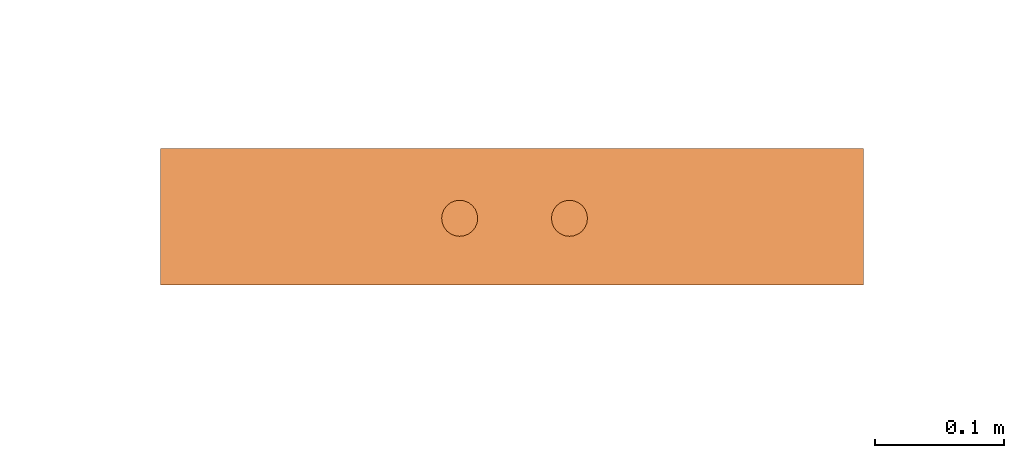
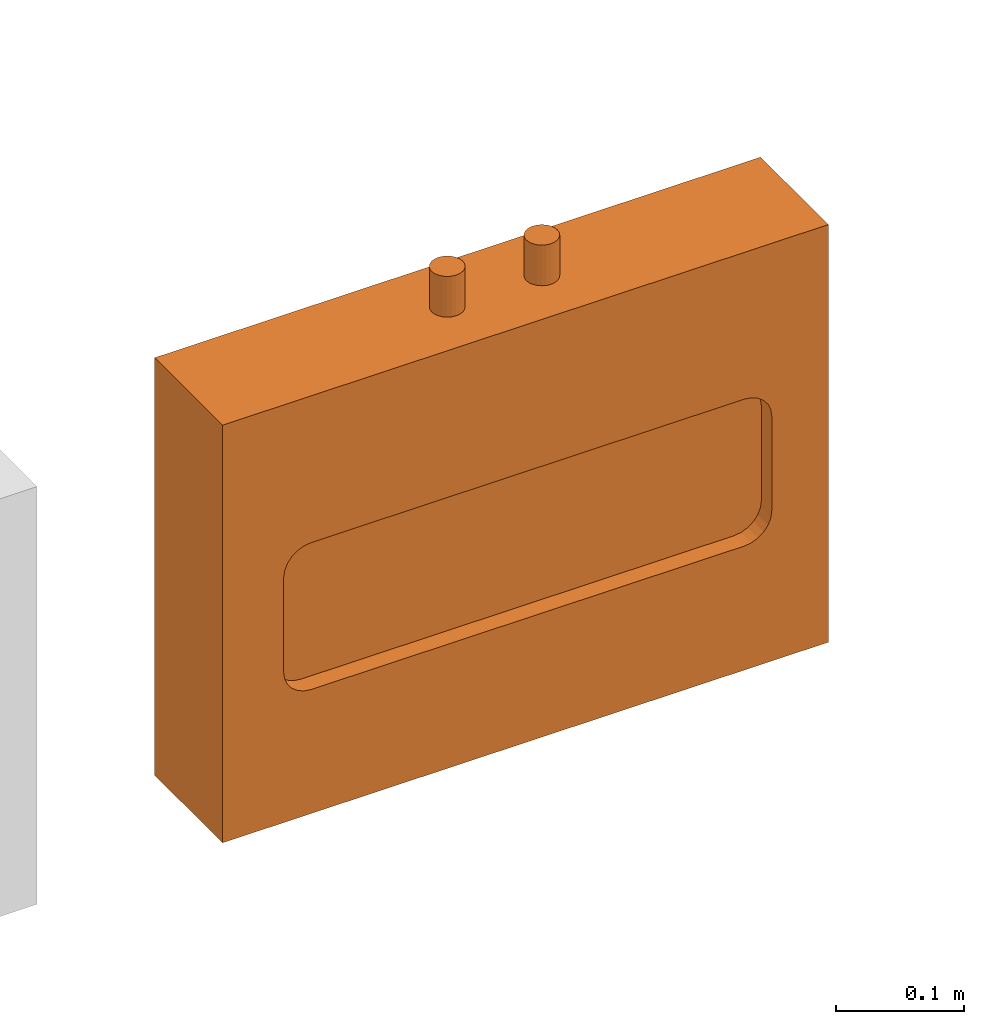
# One storey, part 5 of 5: 1 proxy.
"""IFC2X3 building model written with IfcOpenShell, lengths in millimetres."""

from ifc_helpers import new_model, entity, si_unit, converted_unit, derived_unit, direction, frame, origin, place, context, subcontext, project, spatial, faceted_brep, source, transform, mapped, material, material_list, type_object, type_shapes, element, save


model = new_model("IFC2X3")

# Units and contexts
model_context = context("Model", 3, precision=0.01, world=origin(), true_north=direction((6.12303176911189e-17, 1.0)))
body_context = subcontext(model_context, "Body", "Model", "MODEL_VIEW")
ifc_project = project(units=[si_unit("LENGTHUNIT", "METRE", prefix="MILLI"), si_unit("AREAUNIT", "SQUARE_METRE"), si_unit("VOLUMEUNIT", "CUBIC_METRE"), converted_unit("PLANEANGLEUNIT", "DEGREE", entity("IfcRatioMeasure", 0.0174532925199433), si_unit("PLANEANGLEUNIT", "RADIAN"), dimensions=[0, 0, 0, 0, 0, 0, 0]), si_unit("MASSUNIT", "GRAM", prefix="KILO"), derived_unit("MASSDENSITYUNIT", [(si_unit("MASSUNIT", "GRAM", prefix="KILO"), 1), (si_unit("LENGTHUNIT", "METRE"), -3)]), derived_unit("MOMENTOFINERTIAUNIT", [(si_unit("LENGTHUNIT", "METRE"), 4)]), si_unit("TIMEUNIT", "SECOND"), si_unit("FREQUENCYUNIT", "HERTZ"), si_unit("THERMODYNAMICTEMPERATUREUNIT", "DEGREE_CELSIUS"), derived_unit("THERMALTRANSMITTANCEUNIT", [(si_unit("MASSUNIT", "GRAM", prefix="KILO"), 1), (si_unit("THERMODYNAMICTEMPERATUREUNIT", "KELVIN"), -1), (si_unit("TIMEUNIT", "SECOND"), -3)]), derived_unit("VOLUMETRICFLOWRATEUNIT", [(si_unit("LENGTHUNIT", "METRE"), 3), (si_unit("TIMEUNIT", "SECOND"), -1)]), derived_unit("MASSFLOWRATEUNIT", [(si_unit("MASSUNIT", "GRAM", prefix="KILO"), 1), (si_unit("TIMEUNIT", "SECOND"), -1)]), derived_unit("ROTATIONALFREQUENCYUNIT", [(si_unit("TIMEUNIT", "SECOND"), -1)]), si_unit("ELECTRICCURRENTUNIT", "AMPERE"), si_unit("ELECTRICVOLTAGEUNIT", "VOLT"), si_unit("POWERUNIT", "WATT"), si_unit("FORCEUNIT", "NEWTON", prefix="KILO"), si_unit("ILLUMINANCEUNIT", "LUX"), si_unit("LUMINOUSFLUXUNIT", "LUMEN"), si_unit("LUMINOUSINTENSITYUNIT", "CANDELA"), derived_unit("USERDEFINED", [(si_unit("MASSUNIT", "GRAM", prefix="KILO"), -1), (si_unit("LENGTHUNIT", "METRE"), -2), (si_unit("TIMEUNIT", "SECOND"), 3), (si_unit("LUMINOUSFLUXUNIT", "LUMEN"), 1)]), derived_unit("LINEARVELOCITYUNIT", [(si_unit("LENGTHUNIT", "METRE"), 1), (si_unit("TIMEUNIT", "SECOND"), -1)]), si_unit("PRESSUREUNIT", "PASCAL"), derived_unit("USERDEFINED", [(si_unit("LENGTHUNIT", "METRE"), -2), (si_unit("MASSUNIT", "GRAM", prefix="KILO"), 1), (si_unit("TIMEUNIT", "SECOND"), -2)]), derived_unit("LINEARFORCEUNIT", [(si_unit("MASSUNIT", "GRAM", prefix="KILO"), 1), (si_unit("LENGTHUNIT", "METRE"), 1), (si_unit("TIMEUNIT", "SECOND"), -2), (si_unit("LENGTHUNIT", "METRE"), -1)]), derived_unit("PLANARFORCEUNIT", [(si_unit("MASSUNIT", "GRAM", prefix="KILO"), 1), (si_unit("LENGTHUNIT", "METRE"), 1), (si_unit("TIMEUNIT", "SECOND"), -2), (si_unit("LENGTHUNIT", "METRE"), -2)])], contexts=[model_context])

# Site, building, storey
site_placement = place(None, frame((0.0, 2493.83037508239, 0.0)))
site = spatial("IfcSite", under=ifc_project, at=site_placement, CompositionType="ELEMENT")
building_placement = place(site_placement, origin())
building = spatial("IfcBuilding", under=site, at=building_placement, CompositionType="ELEMENT")
storey_placement = place(building_placement, frame((0.0, 0.0, 19800.0)))
storey = spatial("IfcBuildingStorey", under=building, at=storey_placement, Name="06", CompositionType="ELEMENT", Elevation=19800.0)

# Proxy
ifc_material_1 = material()
ifc_material_2 = material()
ifc_material_list = material_list([ifc_material_1, ifc_material_2])
building_element_proxy_type = type_object("IfcBuildingElementProxyType", PredefinedType="NOTDEFINED", material=ifc_material_1)
shared_shape = source(origin(), body_context, "Body", "Brep", [
    faceted_brep([(55.460649399612, 241.868036996809, 398.0), (58.8371827681767, 240.469431081744, 398.0), (61.7366777047884, 238.244570365374, 398.0), (63.9615384211588, 235.345075428762, 398.0), (65.3601443362237, 231.968542060197, 398.0), (65.8371827681767, 228.345075428762, 398.0), (65.3601443362236, 224.721608797327, 398.0), (63.9615384211588, 221.345075428762, 398.0), (61.7366777047883, 218.44558049215, 398.0), (58.8371827681766, 216.22071977578, 398.0), (55.4606493996119, 214.822113860715, 398.0), (51.8371827681766, 214.345075428762, 398.0), (48.2137161367414, 214.822113860715, 398.0), (44.8371827681767, 216.22071977578, 398.0), (41.937687831565, 218.44558049215, 398.0), (39.7128271151945, 221.345075428762, 398.0), (38.3142212001297, 224.721608797327, 398.0), (37.8371827681767, 228.345075428762, 398.0), (38.3142212001298, 231.968542060197, 398.0), (39.7128271151946, 235.345075428762, 398.0), (41.9376878315651, 238.244570365374, 398.0), (44.8371827681767, 240.469431081744, 398.0), (48.2137161367414, 241.868036996809, 398.0), (51.8371827681767, 242.345075428762, 398.0), (58.8371827681766, 216.22071977578, 436.716690815491), (61.7366777047883, 218.44558049215, 436.716690815491), (63.9615384211588, 221.345075428762, 436.716690815491), (65.3601443362236, 224.721608797327, 436.716690815491), (65.8371827681767, 228.345075428762, 436.716690815491), (65.3601443362237, 231.968542060197, 436.716690815491), (63.9615384211588, 235.345075428762, 436.716690815491), (61.7366777047884, 238.244570365374, 436.716690815491), (58.8371827681767, 240.469431081744, 436.716690815491), (55.460649399612, 241.868036996809, 436.716690815491), (51.8371827681767, 242.345075428762, 436.716690815491), (48.2137161367414, 241.868036996809, 436.716690815491), (44.8371827681767, 240.469431081744, 436.716690815491), (41.9376878315651, 238.244570365374, 436.716690815491), (39.7128271151946, 235.345075428762, 436.716690815491), (38.3142212001298, 231.968542060197, 436.716690815491), (37.8371827681767, 228.345075428762, 436.716690815491), (38.3142212001297, 224.721608797327, 436.716690815491), (39.7128271151945, 221.345075428762, 436.716690815491), (41.937687831565, 218.44558049215, 436.716690815491), (44.8371827681767, 216.22071977578, 436.716690815491), (48.2137161367414, 214.822113860715, 436.716690815491), (51.8371827681766, 214.345075428762, 436.716690815491), (55.4606493996119, 214.822113860715, 436.716690815491)], [[[0, 1, 2, 3, 4, 5, 6, 7, 8, 9, 10, 11, 12, 13, 14, 15, 16, 17, 18, 19, 20, 21, 22, 23]], [[24, 25, 26, 27, 28, 29, 30, 31, 32, 33, 34, 35, 36, 37, 38, 39, 40, 41, 42, 43, 44, 45, 46, 47]], [[40, 17, 16, 41]], [[15, 42, 41, 16]], [[43, 14, 13, 44]], [[15, 14, 43, 42]], [[44, 13, 12, 45]], [[11, 46, 45, 12]], [[47, 10, 9, 24]], [[8, 25, 24, 9]], [[26, 7, 6, 27]], [[8, 7, 26, 25]], [[27, 6, 5, 28]], [[47, 46, 11, 10]], [[28, 5, 4, 29]], [[3, 30, 29, 4]], [[31, 2, 1, 32]], [[3, 2, 31, 30]], [[32, 1, 0, 33]], [[23, 34, 33, 0]], [[35, 22, 21, 36]], [[20, 37, 36, 21]], [[38, 19, 18, 39]], [[20, 19, 38, 37]], [[39, 18, 17, 40]], [[35, 34, 23, 22]]]),
    faceted_brep([(58.8371827681766, 301.503571322428, 436.716690815491), (61.7366777047883, 303.728432038799, 436.716690815491), (63.9615384211588, 306.627926975411, 436.716690815491), (65.3601443362236, 310.004460343975, 436.716690815491), (65.8371827681767, 313.627926975411, 436.716690815491), (65.3601443362237, 317.251393606846, 436.716690815491), (63.9615384211589, 320.627926975411, 436.716690815491), (61.7366777047884, 323.527421912022, 436.716690815491), (58.8371827681767, 325.752282628393, 436.716690815491), (55.460649399612, 327.150888543458, 436.716690815491), (51.8371827681767, 327.627926975411, 436.716690815491), (48.2137161367414, 327.150888543458, 436.716690815491), (44.8371827681767, 325.752282628393, 436.716690815491), (41.9376878315651, 323.527421912022, 436.716690815491), (39.7128271151946, 320.627926975411, 436.716690815491), (38.3142212001298, 317.251393606846, 436.716690815491), (37.8371827681767, 313.627926975411, 436.716690815491), (38.3142212001298, 310.004460343975, 436.716690815491), (39.7128271151945, 306.627926975411, 436.716690815491), (41.937687831565, 303.728432038799, 436.716690815491), (44.8371827681767, 301.503571322429, 436.716690815491), (48.2137161367414, 300.104965407364, 436.716690815491), (51.8371827681766, 299.627926975411, 436.716690815491), (55.4606493996119, 300.104965407364, 436.716690815491), (55.460649399612, 327.150888543458, 398.0), (58.8371827681767, 325.752282628393, 398.0), (61.7366777047884, 323.527421912022, 398.0), (63.9615384211589, 320.627926975411, 398.0), (65.3601443362237, 317.251393606846, 398.0), (65.8371827681767, 313.627926975411, 398.0), (65.3601443362236, 310.004460343975, 398.0), (63.9615384211588, 306.627926975411, 398.0), (61.7366777047883, 303.728432038799, 398.0), (58.8371827681766, 301.503571322428, 398.0), (55.4606493996119, 300.104965407364, 398.0), (51.8371827681766, 299.627926975411, 398.0), (48.2137161367414, 300.104965407364, 398.0), (44.8371827681767, 301.503571322429, 398.0), (41.937687831565, 303.728432038799, 398.0), (39.7128271151945, 306.627926975411, 398.0), (38.3142212001298, 310.004460343975, 398.0), (37.8371827681767, 313.627926975411, 398.0), (38.3142212001298, 317.251393606846, 398.0), (39.7128271151946, 320.627926975411, 398.0), (41.9376878315651, 323.527421912022, 398.0), (44.8371827681767, 325.752282628393, 398.0), (48.2137161367414, 327.150888543458, 398.0), (51.8371827681767, 327.627926975411, 398.0)], [[[0, 1, 2, 3, 4, 5, 6, 7, 8, 9, 10, 11, 12, 13, 14, 15, 16, 17, 18, 19, 20, 21, 22, 23]], [[24, 25, 26, 27, 28, 29, 30, 31, 32, 33, 34, 35, 36, 37, 38, 39, 40, 41, 42, 43, 44, 45, 46, 47]], [[17, 40, 39, 18]], [[38, 19, 18, 39]], [[20, 37, 36, 21]], [[38, 37, 20, 19]], [[21, 36, 35, 22]], [[40, 17, 16, 41]], [[23, 34, 33, 0]], [[32, 1, 0, 33]], [[2, 31, 30, 3]], [[32, 31, 2, 1]], [[3, 30, 29, 4]], [[34, 23, 22, 35]], [[28, 5, 4, 29]], [[27, 6, 5, 28]], [[9, 24, 47, 10]], [[26, 7, 6, 27]], [[25, 8, 7, 26]], [[25, 24, 9, 8]], [[11, 46, 45, 12]], [[44, 13, 12, 45]], [[14, 43, 42, 15]], [[44, 43, 14, 13]], [[15, 42, 41, 16]], [[46, 11, 10, 47]]]),
    faceted_brep([(106.0, 0.0, 0.0), (106.0, 545.986501202085, 0.0), (106.0, 545.986501202086, 398.0), (106.0, 0.0, 398.0), (0.0, 545.986501202086, 398.0), (0.0, 478.486501202086, 254.822902819641), (0.0, 472.456977329649, 257.320413382257), (0.0, 483.66417073175, 250.849937254693), (0.0, 465.986501202086, 258.17226772503), (0.0, 0.0, 398.0), (0.0, 487.637136296697, 245.672267725029), (0.0, 490.134646859313, 239.642743852593), (0.0, 490.986501202086, 233.17226772503), (0.0, 545.986501202085, 0.0), (0.0, 490.986501202086, 143.17226772503), (0.0, 490.134646859313, 136.701791597467), (0.0, 487.637136296697, 130.67226772503), (0.0, 483.66417073175, 125.494598195366), (0.0, 478.486501202086, 121.521632630419), (0.0, 472.456977329649, 119.024122067803), (0.0, 465.986501202086, 118.17226772503), (0.0, 0.0, 0.0), (0.0, 50.9865012020865, 233.17226772503), (0.0, 75.9865012020864, 118.172267725031), (0.0, 69.5160250745231, 119.024122067805), (0.0, 63.4865012020861, 121.521632630421), (0.0, 58.3088316724223, 125.494598195368), (0.0, 54.3358661074751, 130.672267725032), (0.0, 51.8383555448593, 136.701791597469), (0.0, 50.9865012020861, 143.172267725033), (0.0, 51.8383555448597, 239.642743852593), (0.0, 75.9865012020868, 258.17226772503), (0.0, 69.5160250745237, 257.320413382257), (0.0, 63.4865012020866, 254.822902819641), (0.0, 58.3088316724229, 250.849937254693), (0.0, 54.3358661074755, 245.67226772503), (16.2395209800454, 487.637136296697, 245.672267725029), (16.2395209800454, 490.134646859313, 239.642743852593), (16.2395209800454, 490.986501202086, 233.17226772503), (16.2395209800454, 490.986501202086, 143.17226772503), (16.2395209800454, 490.134646859313, 136.701791597467), (16.2395209800454, 487.637136296697, 130.67226772503), (16.2395209800454, 483.66417073175, 125.494598195366), (16.2395209800454, 478.486501202086, 121.521632630419), (16.2395209800454, 472.456977329649, 119.024122067803), (16.2395209800454, 465.986501202086, 118.17226772503), (16.2395209800454, 75.9865012020862, 118.172267725032), (16.2395209800454, 69.5160250745231, 119.024122067805), (16.2395209800454, 63.4865012020861, 121.521632630421), (16.2395209800454, 58.3088316724224, 125.494598195368), (16.2395209800454, 54.3358661074751, 130.672267725032), (16.2395209800454, 51.8383555448594, 136.701791597469), (16.2395209800454, 50.9865012020861, 143.172267725032), (16.2395209800454, 50.9865012020864, 233.17226772503), (16.2395209800454, 51.8383555448597, 239.642743852593), (16.2395209800454, 54.3358661074755, 245.67226772503), (16.2395209800454, 58.3088316724228, 250.849937254694), (16.2395209800454, 63.4865012020866, 254.822902819641), (16.2395209800454, 69.5160250745237, 257.320413382257), (16.2395209800454, 75.9865012020866, 258.17226772503), (16.2395209800454, 465.986501202086, 258.17226772503), (16.2395209800454, 472.456977329649, 257.320413382257), (16.2395209800454, 478.486501202086, 254.822902819641), (16.2395209800454, 483.66417073175, 250.849937254693)], [[[0, 1, 2, 3]], [[4, 5, 6]], [[5, 4, 7]], [[6, 8, 4]], [[4, 8, 9]], [[10, 7, 4]], [[11, 10, 4]], [[12, 11, 4]], [[4, 13, 12]], [[14, 12, 13]], [[15, 14, 13]], [[15, 13, 16]], [[17, 16, 13]], [[13, 18, 17]], [[18, 13, 19]], [[20, 19, 13]], [[13, 21, 20]], [[9, 22, 21]], [[23, 20, 21]], [[24, 23, 21]], [[21, 25, 24]], [[25, 21, 26]], [[27, 26, 21]], [[27, 21, 28]], [[29, 28, 21]], [[29, 21, 22]], [[30, 22, 9]], [[31, 9, 8]], [[31, 32, 9]], [[33, 9, 32]], [[9, 33, 34]], [[34, 35, 9]], [[35, 30, 9]], [[2, 1, 13, 4]], [[3, 2, 4, 9]], [[0, 3, 9, 21]], [[1, 0, 21, 13]], [[36, 37, 38, 39, 40, 41, 42, 43, 44, 45, 46, 47, 48, 49, 50, 51, 52, 53, 54, 55, 56, 57, 58, 59, 60, 61, 62, 63]], [[31, 8, 60, 59]], [[32, 31, 59, 58]], [[33, 32, 58, 57]], [[33, 57, 56, 34]], [[35, 34, 56, 55]], [[30, 35, 55, 54]], [[30, 54, 53, 22]], [[22, 53, 52, 29]], [[28, 29, 52, 51]], [[27, 28, 51, 50]], [[27, 50, 49, 26]], [[25, 26, 49, 48]], [[24, 25, 48, 47]], [[24, 47, 46, 23]], [[20, 23, 46, 45]], [[19, 20, 45, 44]], [[18, 19, 44, 43]], [[18, 43, 42, 17]], [[16, 17, 42, 41]], [[15, 16, 41, 40]], [[15, 40, 39, 14]], [[14, 39, 38, 12]], [[11, 12, 38, 37]], [[10, 11, 37, 36]], [[10, 36, 63, 7]], [[5, 7, 63, 62]], [[6, 5, 62, 61]], [[6, 61, 60, 8]]]),
])
type_shapes(building_element_proxy_type, [shared_shape])
proxy_placement = place(storey_placement, frame((43739.1330860652, 4936.16962491761, 1500.0), z_axis=(0.0, 0.0, 1.0), x_axis=(0.0, 1.0, 0.0)))
element("IfcBuildingElementProxy", 1, at=proxy_placement, inside=storey, type_object=building_element_proxy_type, material=ifc_material_list, context=body_context, shape_type="MappedRepresentation", body=[
    mapped(shared_shape, transform((0.0, 0.0, 0.0), scale=1.0)),
])

save(model, "model.ifc")
